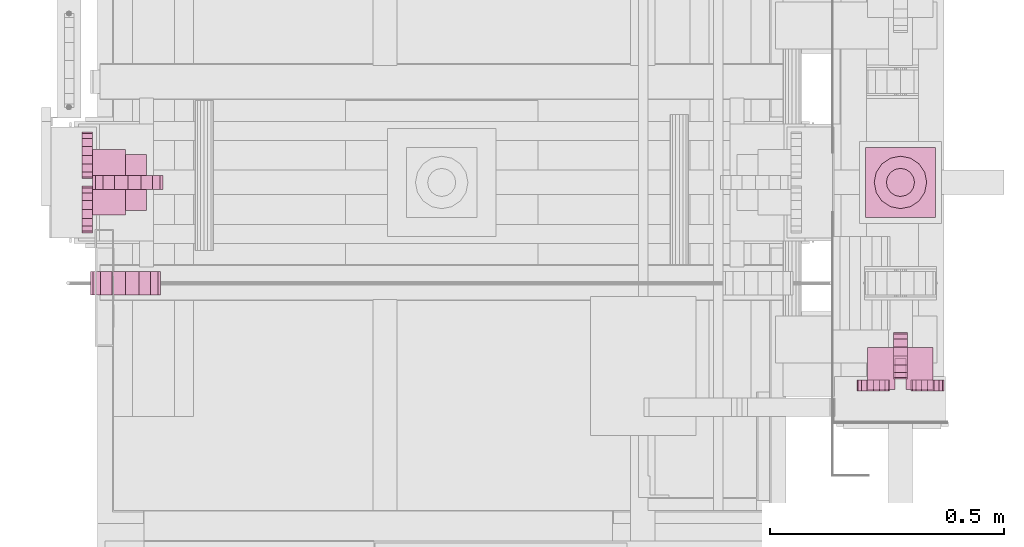
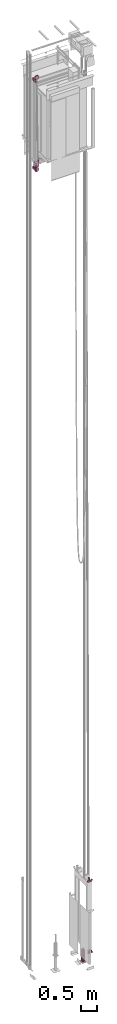
# One storey, part 10 of 13: 6 transport elements.
"""IFC4 building model written with IfcOpenShell, lengths in millimetres."""

from ifc_helpers import new_model, entity, si_unit, converted_unit, frame, origin_with_axes, place, context, subcontext, project, spatial, faceted_brep, element, save


model = new_model("IFC4")

# Units and contexts
context_of_model = context(None, 3, precision=0.01, world=origin_with_axes())
sub_context_1 = subcontext(context_of_model, None, None, "MODEL_VIEW")
sub_context_2 = subcontext(context_of_model, None, None, "MODEL_VIEW")
sub_context_3 = subcontext(context_of_model, None, None, "MODEL_VIEW")
sub_context_4 = subcontext(context_of_model, None, None, "MODEL_VIEW")
sub_context_5 = subcontext(context_of_model, None, None, "MODEL_VIEW")
sub_context_6 = subcontext(context_of_model, None, None, "MODEL_VIEW")
ifc_project = project(units=[converted_unit("PLANEANGLEUNIT", "degree", entity("IfcPlaneAngleMeasure", 0.017453292519943), si_unit("PLANEANGLEUNIT", "RADIAN"), dimensions=[0, 0, 0, 0, 0, 0, 0]), si_unit("LENGTHUNIT", "METRE", prefix="MILLI"), si_unit("MASSUNIT", "GRAM", prefix="KILO"), converted_unit("TIMEUNIT", "year", entity("IfcTimeMeasure", 31557600.0), si_unit("TIMEUNIT", "SECOND"), dimensions=[0, 0, 1, 0, 0, 0, 0]), si_unit("THERMODYNAMICTEMPERATUREUNIT", "DEGREE_CELSIUS"), si_unit("AREAUNIT", "SQUARE_METRE"), si_unit("FORCEUNIT", "NEWTON"), si_unit("VOLUMEUNIT", "CUBIC_METRE"), si_unit("PRESSUREUNIT", "PASCAL"), si_unit("SOLIDANGLEUNIT", "STERADIAN")], contexts=[context_of_model])

# Site, building, storey
site = spatial("IfcSite", under=ifc_project)
building = spatial("IfcBuilding", under=site, Name="Document")
placement = place(None, origin_with_axes())
storey_placement = place(placement, frame((0.0, 0.0, -26400.0), z_axis=(0.0, 0.0, 1.0), x_axis=(1.0, 0.0, 0.0)))
storey = spatial("IfcBuildingStorey", under=building, at=storey_placement, Name="Z -26400", Elevation=-26400.0)

# Transport elements
transport_element_1_placement = place(storey_placement, frame((1879.0, 1025.0, 0.0), z_axis=(0.0, 0.0, 1.0), x_axis=(0.0, 1.0, 0.0)))
element("IfcTransportElement", 1, at=transport_element_1_placement, inside=storey, ObjectType="MLB20", PredefinedType="ELEVATOR", context=sub_context_1, shape_type="Brep", body=[
    faceted_brep([(-75.0, -75.0, 0.0), (-75.0, 75.0, 0.0), (-75.0, 75.0, -16.0), (-75.0, -75.0, -16.0), (75.0, -75.0, 0.0), (75.0, -75.0, -16.0), (75.0, 75.0, -16.0), (75.0, 75.0, 0.0)], [[[0, 1, 2, 3]], [[4, 5, 6, 7]], [[0, 3, 5, 4]], [[3, 2, 6, 5]], [[2, 1, 7, 6]], [[1, 0, 4, 7]]]),
    faceted_brep([(-39.59796142578125, 39.5980224609375, 0.0), (-39.59796142578125, 39.5980224609375, 459.0), (-21.4302978515625, 51.7373046875, 459.0), (-21.4302978515625, 51.7373046875, 0.0), (0.0, 56.0, 0.0), (21.4302978515625, 51.7373046875, 0.0), (39.5980224609375, 39.5980224609375, 0.0), (51.7373046875, 21.4302978515625, 0.0), (56.0, 0.0, 0.0), (51.7373046875, -21.4302978515625, 0.0), (39.5980224609375, -39.5980224609375, 0.0), (21.4302978515625, -51.7373046875, 0.0), (0.0, -56.0, 0.0), (-21.4302978515625, -51.7373046875, 0.0), (-39.59796142578125, -39.5980224609375, 0.0), (-51.73724365234375, -21.4302978515625, 0.0), (-56.0, 0.0, 0.0), (-51.73724365234375, 21.4302978515625, 0.0), (0.0, 56.0, 459.0), (-51.73724365234375, 21.4302978515625, 459.0), (21.4302978515625, 51.7373046875, 459.0), (-56.0, 0.0, 459.0), (39.5980224609375, 39.5980224609375, 459.0), (-51.73724365234375, -21.4302978515625, 459.0), (51.7373046875, 21.4302978515625, 459.0), (-39.59796142578125, -39.5980224609375, 459.0), (56.0, 0.0, 459.0), (-21.4302978515625, -51.7373046875, 459.0), (51.7373046875, -21.4302978515625, 459.0), (0.0, -56.0, 459.0), (39.5980224609375, -39.5980224609375, 459.0), (21.4302978515625, -51.7373046875, 459.0)], [[[0, 1, 2, 3]], [[4, 5, 6, 7, 8, 9, 10, 11, 12, 13, 14, 15, 16, 17, 0, 3]], [[2, 18, 4, 3]], [[17, 19, 1, 0]], [[18, 20, 5, 4]], [[16, 21, 19, 17]], [[20, 22, 6, 5]], [[15, 23, 21, 16]], [[22, 24, 7, 6]], [[14, 25, 23, 15]], [[24, 26, 8, 7]], [[13, 27, 25, 14]], [[26, 28, 9, 8]], [[12, 29, 27, 13]], [[28, 30, 10, 9]], [[11, 31, 29, 12]], [[30, 31, 11, 10]], [[1, 19, 21, 23, 25, 27, 29, 31, 30, 28, 26, 24, 22, 20, 18, 2]]]),
    faceted_brep([(-15.909912109375, 15.909912109375, 459.0), (-15.909912109375, 15.909912109375, 479.0), (-8.6103515625, 20.7872314453125, 479.0), (-8.6103515625, 20.7872314453125, 459.0), (0.0, 22.5, 459.0), (8.6103515625, 20.7872314453125, 459.0), (15.909912109375, 15.909912109375, 459.0), (20.7872314453125, 8.6103515625, 459.0), (22.5, 0.0, 459.0), (20.7872314453125, -8.6103515625, 459.0), (15.909912109375, -15.909912109375, 459.0), (8.6103515625, -20.7872314453125, 459.0), (0.0, -22.5, 459.0), (-8.6103515625, -20.7872314453125, 459.0), (-15.909912109375, -15.909912109375, 459.0), (-20.78729248046875, -8.6103515625, 459.0), (-22.5, 0.0, 459.0), (-20.78729248046875, 8.6103515625, 459.0), (0.0, 22.5, 479.0), (-20.78729248046875, 8.6103515625, 479.0), (8.6103515625, 20.7872314453125, 479.0), (-22.5, 0.0, 479.0), (15.909912109375, 15.909912109375, 479.0), (-20.78729248046875, -8.6103515625, 479.0), (-15.909912109375, -15.909912109375, 479.0), (-8.6103515625, -20.7872314453125, 479.0), (0.0, -22.5, 479.0), (8.6103515625, -20.7872314453125, 479.0), (15.909912109375, -15.909912109375, 479.0), (20.7872314453125, -8.6103515625, 479.0), (22.5, 0.0, 479.0), (20.7872314453125, 8.6103515625, 479.0)], [[[0, 1, 2, 3]], [[4, 5, 6, 7, 8, 9, 10, 11, 12, 13, 14, 15, 16, 17, 0, 3]], [[2, 18, 4, 3]], [[17, 19, 1, 0]], [[18, 20, 5, 4]], [[16, 21, 19, 17]], [[20, 22, 6, 5]], [[1, 19, 21, 23, 24, 25, 26, 27, 28, 29, 30, 31, 22, 20, 18, 2]], [[15, 23, 21, 16]], [[22, 31, 7, 6]], [[14, 24, 23, 15]], [[31, 30, 8, 7]], [[13, 25, 24, 14]], [[30, 29, 9, 8]], [[12, 26, 25, 13]], [[29, 28, 10, 9]], [[11, 27, 26, 12]], [[28, 27, 11, 10]]]),
    faceted_brep([(-21.21319580078125, 21.2132568359375, 479.0), (-21.21319580078125, 21.2132568359375, 489.0), (-11.48052978515625, 27.7164306640625, 489.0), (-11.48052978515625, 27.7164306640625, 479.0), (0.0, 30.0, 479.0), (11.48046875, 27.7164306640625, 479.0), (21.2132568359375, 21.2132568359375, 479.0), (27.7164306640625, 11.48046875, 479.0), (30.0, 0.0, 479.0), (27.7164306640625, -11.48046875, 479.0), (21.2132568359375, -21.2132568359375, 479.0), (11.48046875, -27.7164306640625, 479.0), (0.0, -30.0, 479.0), (-11.48052978515625, -27.7164306640625, 479.0), (-21.21319580078125, -21.2132568359375, 479.0), (-27.71636962890625, -11.48046875, 479.0), (-30.0, 0.0, 479.0), (-27.71636962890625, 11.48046875, 479.0), (0.0, 30.0, 489.0), (-27.71636962890625, 11.48046875, 489.0), (11.48046875, 27.7164306640625, 489.0), (-30.0, 0.0, 489.0), (-27.71636962890625, -11.48046875, 489.0), (-21.21319580078125, -21.2132568359375, 489.0), (-11.48052978515625, -27.7164306640625, 489.0), (0.0, -30.0, 489.0), (11.48046875, -27.7164306640625, 489.0), (21.2132568359375, -21.2132568359375, 489.0), (27.7164306640625, -11.48046875, 489.0), (30.0, 0.0, 489.0), (27.7164306640625, 11.48046875, 489.0), (21.2132568359375, 21.2132568359375, 489.0)], [[[0, 1, 2, 3]], [[4, 5, 6, 7, 8, 9, 10, 11, 12, 13, 14, 15, 16, 17, 0, 3]], [[2, 18, 4, 3]], [[17, 19, 1, 0]], [[18, 20, 5, 4]], [[1, 19, 21, 22, 23, 24, 25, 26, 27, 28, 29, 30, 31, 20, 18, 2]], [[16, 21, 19, 17]], [[20, 31, 6, 5]], [[15, 22, 21, 16]], [[31, 30, 7, 6]], [[14, 23, 22, 15]], [[30, 29, 8, 7]], [[13, 24, 23, 14]], [[29, 28, 9, 8]], [[12, 25, 24, 13]], [[28, 27, 10, 9]], [[11, 26, 25, 12]], [[27, 26, 11, 10]]]),
])
transport_element_2_placement = place(storey_placement, frame((1879.0, 603.0, 649.0), z_axis=(0.0, 0.0, -1.0), x_axis=(1.0, 0.0, 0.0)))
element("IfcTransportElement", 2, at=transport_element_2_placement, inside=storey, ObjectType="R3", PredefinedType="ELEVATOR", context=sub_context_2, shape_type="Brep", body=[
    faceted_brep([(-70.0, 20.0, 0.0), (-70.0, -70.0, 0.0), (-70.0, -70.0, 10.0), (-70.0, 20.0, 10.0), (-12.0, -46.0, 10.0), (-12.0, -46.0, 0.0), (-12.0, 20.0, 0.0), (-12.0, 20.0, 10.0), (12.0, 20.0, 0.0), (12.0, -46.0, 0.0), (12.0, -46.0, 10.0), (12.0, 20.0, 10.0), (70.0, -70.0, 10.0), (70.0, -70.0, 0.0), (70.0, 20.0, 0.0), (70.0, 20.0, 10.0)], [[[0, 1, 2, 3]], [[4, 5, 6, 7]], [[8, 9, 10, 11]], [[12, 13, 14, 15]], [[7, 6, 0, 3]], [[1, 13, 12, 2]], [[15, 14, 8, 11]], [[10, 9, 5, 4]], [[2, 12, 15, 11, 10, 4, 7, 3]], [[6, 5, 9, 8, 14, 13, 1, 0]]]),
    faceted_brep([(22.93994140625, 23.0, 58.0), (25.604248046875, 23.0, 71.3939208984375), (33.1912841796875, 23.0, 82.74871826171875), (44.5460205078125, 23.0, 90.33575439453125), (57.93994140625, 23.0, 93.0), (71.3338623046875, 23.0, 90.33575439453125), (82.688720703125, 23.0, 82.74871826171875), (90.2757568359375, 23.0, 71.3939208984375), (92.93994140625, 23.0, 58.0), (90.2757568359375, 23.0, 44.6060791015625), (82.688720703125, 23.0, 33.25128173828125), (71.3338623046875, 23.0, 25.66424560546875), (57.93994140625, 23.0, 23.0), (44.5460205078125, 23.0, 25.66424560546875), (33.1912841796875, 23.0, 33.25128173828125), (25.604248046875, 23.0, 44.6060791015625), (22.93994140625, 0.0, 58.0), (25.604248046875, 0.0, 44.6060791015625), (33.1912841796875, 0.0, 33.25128173828125), (44.5460205078125, 0.0, 25.66424560546875), (57.93994140625, 0.0, 23.0), (71.3338623046875, 0.0, 25.66424560546875), (82.688720703125, 0.0, 33.25128173828125), (90.2757568359375, 0.0, 44.6060791015625), (92.93994140625, 0.0, 58.0), (90.2757568359375, 0.0, 71.3939208984375), (82.688720703125, 0.0, 82.74871826171875), (71.3338623046875, 0.0, 90.33575439453125), (57.93994140625, 0.0, 93.0), (44.5460205078125, 0.0, 90.33575439453125), (33.1912841796875, 0.0, 82.74871826171875), (25.604248046875, 0.0, 71.3939208984375)], [[[0, 1, 2, 3, 4, 5, 6, 7, 8, 9, 10, 11, 12, 13, 14, 15]], [[16, 17, 18, 19, 20, 21, 22, 23, 24, 25, 26, 27, 28, 29, 30, 31]], [[0, 15, 17, 16]], [[15, 14, 18, 17]], [[14, 13, 19, 18]], [[13, 12, 20, 19]], [[12, 11, 21, 20]], [[11, 10, 22, 21]], [[10, 9, 23, 22]], [[9, 8, 24, 23]], [[8, 7, 25, 24]], [[7, 6, 26, 25]], [[6, 5, 27, 26]], [[5, 4, 28, 27]], [[4, 3, 29, 28]], [[3, 2, 30, 29]], [[2, 1, 31, 30]], [[1, 0, 16, 31]]]),
    faceted_brep([(-92.93994140625, 0.0, 58.0), (-90.2757568359375, 0.0, 44.6060791015625), (-82.688720703125, 0.0, 33.25128173828125), (-71.3338623046875, 0.0, 25.66424560546875), (-57.93994140625, 0.0, 23.0), (-44.5460205078125, 0.0, 25.66424560546875), (-33.1912841796875, 0.0, 33.25128173828125), (-25.604248046875, 0.0, 44.6060791015625), (-22.93994140625, 0.0, 58.0), (-25.604248046875, 0.0, 71.3939208984375), (-33.1912841796875, 0.0, 82.74871826171875), (-44.5460205078125, 0.0, 90.33575439453125), (-57.93994140625, 0.0, 93.0), (-71.3338623046875, 0.0, 90.33575439453125), (-82.688720703125, 0.0, 82.74871826171875), (-90.2757568359375, 0.0, 71.3939208984375), (-92.93994140625, 23.0, 58.0), (-90.2757568359375, 23.0, 71.3939208984375), (-82.688720703125, 23.0, 82.74871826171875), (-71.3338623046875, 23.0, 90.33575439453125), (-57.93994140625, 23.0, 93.0), (-44.5460205078125, 23.0, 90.33575439453125), (-33.1912841796875, 23.0, 82.74871826171875), (-25.604248046875, 23.0, 71.3939208984375), (-22.93994140625, 23.0, 58.0), (-25.604248046875, 23.0, 44.6060791015625), (-33.1912841796875, 23.0, 33.25128173828125), (-44.5460205078125, 23.0, 25.66424560546875), (-57.93994140625, 23.0, 23.0), (-71.3338623046875, 23.0, 25.66424560546875), (-82.688720703125, 23.0, 33.25128173828125), (-90.2757568359375, 23.0, 44.6060791015625)], [[[0, 1, 2, 3, 4, 5, 6, 7, 8, 9, 10, 11, 12, 13, 14, 15]], [[16, 17, 18, 19, 20, 21, 22, 23, 24, 25, 26, 27, 28, 29, 30, 31]], [[0, 15, 17, 16]], [[15, 14, 18, 17]], [[14, 13, 19, 18]], [[13, 12, 20, 19]], [[12, 11, 21, 20]], [[11, 10, 22, 21]], [[10, 9, 23, 22]], [[9, 8, 24, 23]], [[8, 7, 25, 24]], [[7, 6, 26, 25]], [[6, 5, 27, 26]], [[5, 4, 28, 27]], [[4, 3, 29, 28]], [[3, 2, 30, 29]], [[2, 1, 31, 30]], [[1, 0, 16, 31]]]),
    faceted_brep([(15.0, -52.0, 43.0), (15.0, -32.8658447265625, 46.8060302734375), (15.0, -16.6446533203125, 57.6446533203125), (15.0, -5.8060302734375, 73.8658447265625), (15.0, -2.0, 93.0), (15.0, -5.8060302734375, 112.1341552734375), (15.0, -16.6446533203125, 128.3553466796875), (15.0, -32.8658447265625, 139.1939697265625), (15.0, -52.0, 143.0), (15.0, -71.1341552734375, 139.1939697265625), (15.0, -87.3553466796875, 128.3553466796875), (15.0, -98.1939697265625, 112.1341552734375), (15.0, -102.0, 93.0), (15.0, -98.1939697265625, 73.8658447265625), (15.0, -87.3553466796875, 57.6446533203125), (15.0, -71.1341552734375, 46.8060302734375), (-15.0, -52.0, 43.0), (-15.0, -71.1341552734375, 46.8060302734375), (-15.0, -87.3553466796875, 57.6446533203125), (-15.0, -98.1939697265625, 73.8658447265625), (-15.0, -102.0, 93.0), (-15.0, -98.1939697265625, 112.1341552734375), (-15.0, -87.3553466796875, 128.3553466796875), (-15.0, -71.1341552734375, 139.1939697265625), (-15.0, -52.0, 143.0), (-15.0, -32.8658447265625, 139.1939697265625), (-15.0, -16.6446533203125, 128.3553466796875), (-15.0, -5.8060302734375, 112.1341552734375), (-15.0, -2.0, 93.0), (-15.0, -5.8060302734375, 73.8658447265625), (-15.0, -16.6446533203125, 57.6446533203125), (-15.0, -32.8658447265625, 46.8060302734375)], [[[0, 1, 2, 3, 4, 5, 6, 7, 8, 9, 10, 11, 12, 13, 14, 15]], [[16, 17, 18, 19, 20, 21, 22, 23, 24, 25, 26, 27, 28, 29, 30, 31]], [[0, 15, 17, 16]], [[15, 14, 18, 17]], [[14, 13, 19, 18]], [[13, 12, 20, 19]], [[12, 11, 21, 20]], [[11, 10, 22, 21]], [[10, 9, 23, 22]], [[9, 8, 24, 23]], [[8, 7, 25, 24]], [[7, 6, 26, 25]], [[6, 5, 27, 26]], [[5, 4, 28, 27]], [[4, 3, 29, 28]], [[3, 2, 30, 29]], [[2, 1, 31, 30]], [[1, 0, 16, 31]]]),
])
transport_element_3_placement = place(storey_placement, frame((1879.0, 603.0, 3249.0), z_axis=(0.0, 0.0, 1.0), x_axis=(-1.0, 0.0, 0.0)))
element("IfcTransportElement", 3, at=transport_element_3_placement, inside=storey, ObjectType="R3", PredefinedType="ELEVATOR", context=sub_context_3, shape_type="Brep", body=[
    faceted_brep([(15.0, -52.0, 43.0), (15.0, -32.8658447265625, 46.805908203125), (15.0, -16.6446533203125, 57.644775390625), (15.0, -5.8060302734375, 73.86572265625), (15.0, -2.0, 93.0), (15.0, -5.8060302734375, 112.13427734375), (15.0, -16.6446533203125, 128.355224609375), (15.0, -32.8658447265625, 139.194091796875), (15.0, -52.0, 143.0), (15.0, -71.1341552734375, 139.194091796875), (15.0, -87.3553466796875, 128.355224609375), (15.0, -98.1939697265625, 112.13427734375), (15.0, -102.0, 93.0), (15.0, -98.1939697265625, 73.86572265625), (15.0, -87.3553466796875, 57.644775390625), (15.0, -71.1341552734375, 46.805908203125), (-15.0, -52.0, 43.0), (-15.0, -71.1341552734375, 46.805908203125), (-15.0, -87.3553466796875, 57.644775390625), (-15.0, -98.1939697265625, 73.86572265625), (-15.0, -102.0, 93.0), (-15.0, -98.1939697265625, 112.13427734375), (-15.0, -87.3553466796875, 128.355224609375), (-15.0, -71.1341552734375, 139.194091796875), (-15.0, -52.0, 143.0), (-15.0, -32.8658447265625, 139.194091796875), (-15.0, -16.6446533203125, 128.355224609375), (-15.0, -5.8060302734375, 112.13427734375), (-15.0, -2.0, 93.0), (-15.0, -5.8060302734375, 73.86572265625), (-15.0, -16.6446533203125, 57.644775390625), (-15.0, -32.8658447265625, 46.805908203125)], [[[0, 1, 2, 3, 4, 5, 6, 7, 8, 9, 10, 11, 12, 13, 14, 15]], [[16, 17, 18, 19, 20, 21, 22, 23, 24, 25, 26, 27, 28, 29, 30, 31]], [[0, 15, 17, 16]], [[15, 14, 18, 17]], [[14, 13, 19, 18]], [[13, 12, 20, 19]], [[12, 11, 21, 20]], [[11, 10, 22, 21]], [[10, 9, 23, 22]], [[9, 8, 24, 23]], [[8, 7, 25, 24]], [[7, 6, 26, 25]], [[6, 5, 27, 26]], [[5, 4, 28, 27]], [[4, 3, 29, 28]], [[3, 2, 30, 29]], [[2, 1, 31, 30]], [[1, 0, 16, 31]]]),
    faceted_brep([(-92.93994140625, 0.0, 58.0), (-90.2757568359375, 0.0, 44.606201171875), (-82.688720703125, 0.0, 33.251220703125), (-71.3338623046875, 0.0, 25.664306640625), (-57.93994140625, 0.0, 23.0), (-44.5460205078125, 0.0, 25.664306640625), (-33.1912841796875, 0.0, 33.251220703125), (-25.604248046875, 0.0, 44.606201171875), (-22.93994140625, 0.0, 58.0), (-25.604248046875, 0.0, 71.393798828125), (-33.1912841796875, 0.0, 82.748779296875), (-44.5460205078125, 0.0, 90.335693359375), (-57.93994140625, 0.0, 93.0), (-71.3338623046875, 0.0, 90.335693359375), (-82.688720703125, 0.0, 82.748779296875), (-90.2757568359375, 0.0, 71.393798828125), (-92.93994140625, 23.0, 58.0), (-90.2757568359375, 23.0, 71.393798828125), (-82.688720703125, 23.0, 82.748779296875), (-71.3338623046875, 23.0, 90.335693359375), (-57.93994140625, 23.0, 93.0), (-44.5460205078125, 23.0, 90.335693359375), (-33.1912841796875, 23.0, 82.748779296875), (-25.604248046875, 23.0, 71.393798828125), (-22.93994140625, 23.0, 58.0), (-25.604248046875, 23.0, 44.606201171875), (-33.1912841796875, 23.0, 33.251220703125), (-44.5460205078125, 23.0, 25.664306640625), (-57.93994140625, 23.0, 23.0), (-71.3338623046875, 23.0, 25.664306640625), (-82.688720703125, 23.0, 33.251220703125), (-90.2757568359375, 23.0, 44.606201171875)], [[[0, 1, 2, 3, 4, 5, 6, 7, 8, 9, 10, 11, 12, 13, 14, 15]], [[16, 17, 18, 19, 20, 21, 22, 23, 24, 25, 26, 27, 28, 29, 30, 31]], [[0, 15, 17, 16]], [[15, 14, 18, 17]], [[14, 13, 19, 18]], [[13, 12, 20, 19]], [[12, 11, 21, 20]], [[11, 10, 22, 21]], [[10, 9, 23, 22]], [[9, 8, 24, 23]], [[8, 7, 25, 24]], [[7, 6, 26, 25]], [[6, 5, 27, 26]], [[5, 4, 28, 27]], [[4, 3, 29, 28]], [[3, 2, 30, 29]], [[2, 1, 31, 30]], [[1, 0, 16, 31]]]),
    faceted_brep([(22.93994140625, 23.0, 58.0), (25.604248046875, 23.0, 71.393798828125), (33.1912841796875, 23.0, 82.748779296875), (44.5460205078125, 23.0, 90.335693359375), (57.93994140625, 23.0, 93.0), (71.3338623046875, 23.0, 90.335693359375), (82.688720703125, 23.0, 82.748779296875), (90.2757568359375, 23.0, 71.393798828125), (92.93994140625, 23.0, 58.0), (90.2757568359375, 23.0, 44.606201171875), (82.688720703125, 23.0, 33.251220703125), (71.3338623046875, 23.0, 25.664306640625), (57.93994140625, 23.0, 23.0), (44.5460205078125, 23.0, 25.664306640625), (33.1912841796875, 23.0, 33.251220703125), (25.604248046875, 23.0, 44.606201171875), (22.93994140625, 0.0, 58.0), (25.604248046875, 0.0, 44.606201171875), (33.1912841796875, 0.0, 33.251220703125), (44.5460205078125, 0.0, 25.664306640625), (57.93994140625, 0.0, 23.0), (71.3338623046875, 0.0, 25.664306640625), (82.688720703125, 0.0, 33.251220703125), (90.2757568359375, 0.0, 44.606201171875), (92.93994140625, 0.0, 58.0), (90.2757568359375, 0.0, 71.393798828125), (82.688720703125, 0.0, 82.748779296875), (71.3338623046875, 0.0, 90.335693359375), (57.93994140625, 0.0, 93.0), (44.5460205078125, 0.0, 90.335693359375), (33.1912841796875, 0.0, 82.748779296875), (25.604248046875, 0.0, 71.393798828125)], [[[0, 1, 2, 3, 4, 5, 6, 7, 8, 9, 10, 11, 12, 13, 14, 15]], [[16, 17, 18, 19, 20, 21, 22, 23, 24, 25, 26, 27, 28, 29, 30, 31]], [[0, 15, 17, 16]], [[15, 14, 18, 17]], [[14, 13, 19, 18]], [[13, 12, 20, 19]], [[12, 11, 21, 20]], [[11, 10, 22, 21]], [[10, 9, 23, 22]], [[9, 8, 24, 23]], [[8, 7, 25, 24]], [[7, 6, 26, 25]], [[6, 5, 27, 26]], [[5, 4, 28, 27]], [[4, 3, 29, 28]], [[3, 2, 30, 29]], [[2, 1, 31, 30]], [[1, 0, 16, 31]]]),
    faceted_brep([(70.0, 20.0, 10.0), (70.0, -70.0, 10.0), (70.0, -70.0, 0.0), (70.0, 20.0, 0.0), (12.0, -46.0, 0.0), (12.0, -46.0, 10.0), (12.0, 20.0, 10.0), (12.0, 20.0, 0.0), (-12.0, 20.0, 10.0), (-12.0, -46.0, 10.0), (-12.0, -46.0, 0.0), (-12.0, 20.0, 0.0), (-70.0, -70.0, 0.0), (-70.0, -70.0, 10.0), (-70.0, 20.0, 10.0), (-70.0, 20.0, 0.0)], [[[0, 1, 2, 3]], [[4, 5, 6, 7]], [[8, 9, 10, 11]], [[12, 13, 14, 15]], [[7, 6, 0, 3]], [[1, 13, 12, 2]], [[15, 14, 8, 11]], [[10, 9, 5, 4]], [[2, 12, 15, 11, 10, 4, 7, 3]], [[6, 5, 9, 8, 14, 13, 1, 0]]]),
])
transport_element_4_placement = place(storey_placement, frame((155.0, 1025.0, 30670.0), z_axis=(0.0, 0.0, -1.0), x_axis=(0.0, -1.0, 0.0)))
element("IfcTransportElement", 4, at=transport_element_4_placement, inside=storey, ObjectType="Car Guide shoe Bottom", PredefinedType="ELEVATOR", context=sub_context_4, shape_type="Brep", body=[
    faceted_brep([(15.0, -75.0, 204.0), (15.0, -46.298736572265625, 209.708984375), (15.0, -21.966995239257812, 225.966796875), (15.0, -5.709030151367188, 250.298828125), (15.0, 0.0, 279.0), (15.0, -5.709030151367188, 307.701171875), (15.0, -21.966995239257812, 332.033203125), (15.0, -46.298736572265625, 348.291015625), (15.0, -75.0, 354.0), (15.0, -103.70126342773438, 348.291015625), (15.0, -128.03302001953125, 332.033203125), (15.0, -144.29095458984375, 307.701171875), (15.0, -150.0, 279.0), (15.0, -144.29095458984375, 250.298828125), (15.0, -128.03302001953125, 225.966796875), (15.0, -103.70126342773438, 209.708984375), (-15.0, -75.0, 204.0), (-15.0, -103.70126342773438, 209.708984375), (-15.0, -128.03302001953125, 225.966796875), (-15.0, -144.29095458984375, 250.298828125), (-15.0, -150.0, 279.0), (-15.0, -144.29095458984375, 307.701171875), (-15.0, -128.03302001953125, 332.033203125), (-15.0, -103.70126342773438, 348.291015625), (-15.0, -75.0, 354.0), (-15.0, -46.298736572265625, 348.291015625), (-15.0, -21.966995239257812, 332.033203125), (-15.0, -5.709030151367188, 307.701171875), (-15.0, 0.0, 279.0), (-15.0, -5.709030151367188, 250.298828125), (-15.0, -21.966995239257812, 225.966796875), (-15.0, -46.298736572265625, 209.708984375)], [[[0, 1, 2, 3, 4, 5, 6, 7, 8, 9, 10, 11, 12, 13, 14, 15]], [[16, 17, 18, 19, 20, 21, 22, 23, 24, 25, 26, 27, 28, 29, 30, 31]], [[0, 15, 17, 16]], [[15, 14, 18, 17]], [[14, 13, 19, 18]], [[13, 12, 20, 19]], [[12, 11, 21, 20]], [[11, 10, 22, 21]], [[10, 9, 23, 22]], [[9, 8, 24, 23]], [[8, 7, 25, 24]], [[7, 6, 26, 25]], [[6, 5, 27, 26]], [[5, 4, 28, 27]], [[4, 3, 29, 28]], [[3, 2, 30, 29]], [[2, 1, 31, 30]], [[1, 0, 16, 31]]]),
    faceted_brep([(-107.93994140625, 0.0, 213.0), (-104.134033203125, 0.0, 193.865234375), (-93.2952880859375, 0.0, 177.64453125), (-77.07421875, 0.0, 166.806640625), (-57.93994140625, 0.0, 163.0), (-38.8057861328125, 0.0, 166.806640625), (-22.584716796875, 0.0, 177.64453125), (-11.7459716796875, 0.0, 193.865234375), (-7.93994140625, 0.0, 213.0), (-11.7459716796875, 0.0, 232.134765625), (-22.584716796875, 0.0, 248.35546875), (-38.8057861328125, 0.0, 259.193359375), (-57.93994140625, 0.0, 263.0), (-77.07421875, 0.0, 259.193359375), (-93.2952880859375, 0.0, 248.35546875), (-104.134033203125, 0.0, 232.134765625), (-107.93994140625, 23.0, 213.0), (-104.134033203125, 23.0, 232.134765625), (-93.2952880859375, 23.0, 248.35546875), (-77.07421875, 23.0, 259.193359375), (-57.93994140625, 23.0, 263.0), (-38.8057861328125, 23.0, 259.193359375), (-22.584716796875, 23.0, 248.35546875), (-11.7459716796875, 23.0, 232.134765625), (-7.93994140625, 23.0, 213.0), (-11.7459716796875, 23.0, 193.865234375), (-22.584716796875, 23.0, 177.64453125), (-38.8057861328125, 23.0, 166.806640625), (-57.93994140625, 23.0, 163.0), (-77.07421875, 23.0, 166.806640625), (-93.2952880859375, 23.0, 177.64453125), (-104.134033203125, 23.0, 193.865234375)], [[[0, 1, 2, 3, 4, 5, 6, 7, 8, 9, 10, 11, 12, 13, 14, 15]], [[16, 17, 18, 19, 20, 21, 22, 23, 24, 25, 26, 27, 28, 29, 30, 31]], [[0, 15, 17, 16]], [[15, 14, 18, 17]], [[14, 13, 19, 18]], [[13, 12, 20, 19]], [[12, 11, 21, 20]], [[11, 10, 22, 21]], [[10, 9, 23, 22]], [[9, 8, 24, 23]], [[8, 7, 25, 24]], [[7, 6, 26, 25]], [[6, 5, 27, 26]], [[5, 4, 28, 27]], [[4, 3, 29, 28]], [[3, 2, 30, 29]], [[2, 1, 31, 30]], [[1, 0, 16, 31]]]),
    faceted_brep([(-60.0, -15.0, 0.0), (-60.0, -115.0, 0.0), (-60.0, -115.0, 145.0), (-60.0, -15.0, 145.0), (60.0, -15.0, 0.0), (60.0, -15.0, 145.0), (60.0, -115.0, 145.0), (60.0, -115.0, 0.0)], [[[0, 1, 2, 3]], [[4, 5, 6, 7]], [[0, 3, 5, 4]], [[3, 2, 6, 5]], [[2, 1, 7, 6]], [[1, 0, 4, 7]]]),
    faceted_brep([(7.94000244140625, 23.0, 213.0), (11.74603271484375, 23.0, 232.134765625), (22.58465576171875, 23.0, 248.35546875), (38.80584716796875, 23.0, 259.193359375), (57.94000244140625, 23.0, 263.0), (77.07415771484375, 23.0, 259.193359375), (93.29534912109375, 23.0, 248.35546875), (104.13397216796875, 23.0, 232.134765625), (107.94000244140625, 23.0, 213.0), (104.13397216796875, 23.0, 193.865234375), (93.29534912109375, 23.0, 177.64453125), (77.07415771484375, 23.0, 166.806640625), (57.94000244140625, 23.0, 163.0), (38.80584716796875, 23.0, 166.806640625), (22.58465576171875, 23.0, 177.64453125), (11.74603271484375, 23.0, 193.865234375), (7.94000244140625, 0.0, 213.0), (11.74603271484375, 0.0, 193.865234375), (22.58465576171875, 0.0, 177.64453125), (38.80584716796875, 0.0, 166.806640625), (57.94000244140625, 0.0, 163.0), (77.07415771484375, 0.0, 166.806640625), (93.29534912109375, 0.0, 177.64453125), (104.13397216796875, 0.0, 193.865234375), (107.94000244140625, 0.0, 213.0), (104.13397216796875, 0.0, 232.134765625), (93.29534912109375, 0.0, 248.35546875), (77.07415771484375, 0.0, 259.193359375), (57.94000244140625, 0.0, 263.0), (38.80584716796875, 0.0, 259.193359375), (22.58465576171875, 0.0, 248.35546875), (11.74603271484375, 0.0, 232.134765625)], [[[0, 1, 2, 3, 4, 5, 6, 7, 8, 9, 10, 11, 12, 13, 14, 15]], [[16, 17, 18, 19, 20, 21, 22, 23, 24, 25, 26, 27, 28, 29, 30, 31]], [[0, 15, 17, 16]], [[15, 14, 18, 17]], [[14, 13, 19, 18]], [[13, 12, 20, 19]], [[12, 11, 21, 20]], [[11, 10, 22, 21]], [[10, 9, 23, 22]], [[9, 8, 24, 23]], [[8, 7, 25, 24]], [[7, 6, 26, 25]], [[6, 5, 27, 26]], [[5, 4, 28, 27]], [[4, 3, 29, 28]], [[3, 2, 30, 29]], [[2, 1, 31, 30]], [[1, 0, 16, 31]]]),
    faceted_brep([(70.0, 20.0, 145.0), (12.0, 20.0, 145.0), (12.0, 20.0, 155.0), (70.0, 20.0, 155.0), (-12.0, 20.0, 145.0), (-70.0, 20.0, 145.0), (-70.0, 20.0, 155.0), (-12.0, 20.0, 155.0), (-70.0, -70.0, 155.0), (-70.0, -70.0, 145.0), (70.0, -70.0, 145.0), (70.0, -70.0, 155.0), (12.0, -46.0, 145.0), (-12.0, -46.0, 145.0), (-12.0, -46.0, 155.0), (12.0, -46.0, 155.0)], [[[0, 1, 2, 3]], [[4, 5, 6, 7]], [[8, 9, 10, 11]], [[12, 13, 14, 15]], [[11, 10, 0, 3]], [[1, 12, 15, 2]], [[14, 13, 4, 7]], [[5, 9, 8, 6]], [[2, 15, 14, 7, 6, 8, 11, 3]], [[10, 9, 5, 4, 13, 12, 1, 0]]]),
])
transport_element_5_placement = place(storey_placement, frame((155.0, 1025.0, 33729.0), z_axis=(0.0, 0.0, 1.0), x_axis=(0.0, 1.0, 0.0)))
element("IfcTransportElement", 5, at=transport_element_5_placement, inside=storey, ObjectType="Car Guide shoe Top", PredefinedType="ELEVATOR", context=sub_context_5, shape_type="Brep", body=[
    faceted_brep([(15.0, -75.0, 59.0), (15.0, -46.298736572265625, 64.7109375), (15.0, -21.966995239257812, 80.96875), (15.0, -5.709030151367188, 105.296875), (15.0, 0.0, 134.0), (15.0, -5.709030151367188, 162.703125), (15.0, -21.966995239257812, 187.03125), (15.0, -46.298736572265625, 203.2890625), (15.0, -75.0, 209.0), (15.0, -103.70126342773438, 203.2890625), (15.0, -128.03302001953125, 187.03125), (15.0, -144.29095458984375, 162.703125), (15.0, -150.0, 134.0), (15.0, -144.29095458984375, 105.296875), (15.0, -128.03302001953125, 80.96875), (15.0, -103.70126342773438, 64.7109375), (-15.0, -75.0, 59.0), (-15.0, -103.70126342773438, 64.7109375), (-15.0, -128.03302001953125, 80.96875), (-15.0, -144.29095458984375, 105.296875), (-15.0, -150.0, 134.0), (-15.0, -144.29095458984375, 162.703125), (-15.0, -128.03302001953125, 187.03125), (-15.0, -103.70126342773438, 203.2890625), (-15.0, -75.0, 209.0), (-15.0, -46.298736572265625, 203.2890625), (-15.0, -21.966995239257812, 187.03125), (-15.0, -5.709030151367188, 162.703125), (-15.0, 0.0, 134.0), (-15.0, -5.709030151367188, 105.296875), (-15.0, -21.966995239257812, 80.96875), (-15.0, -46.298736572265625, 64.7109375)], [[[0, 1, 2, 3, 4, 5, 6, 7, 8, 9, 10, 11, 12, 13, 14, 15]], [[16, 17, 18, 19, 20, 21, 22, 23, 24, 25, 26, 27, 28, 29, 30, 31]], [[0, 15, 17, 16]], [[15, 14, 18, 17]], [[14, 13, 19, 18]], [[13, 12, 20, 19]], [[12, 11, 21, 20]], [[11, 10, 22, 21]], [[10, 9, 23, 22]], [[9, 8, 24, 23]], [[8, 7, 25, 24]], [[7, 6, 26, 25]], [[6, 5, 27, 26]], [[5, 4, 28, 27]], [[4, 3, 29, 28]], [[3, 2, 30, 29]], [[2, 1, 31, 30]], [[1, 0, 16, 31]]]),
    faceted_brep([(-70.0, 20.0, 10.0), (-12.0, 20.0, 10.0), (-12.0, 20.0, 0.0), (-70.0, 20.0, 0.0), (12.0, 20.0, 10.0), (70.0, 20.0, 10.0), (70.0, 20.0, 0.0), (12.0, 20.0, 0.0), (70.0, -70.0, 0.0), (70.0, -70.0, 10.0), (-70.0, -70.0, 10.0), (-70.0, -70.0, 0.0), (-12.0, -46.0, 10.0), (12.0, -46.0, 10.0), (12.0, -46.0, 0.0), (-12.0, -46.0, 0.0)], [[[0, 1, 2, 3]], [[4, 5, 6, 7]], [[8, 9, 10, 11]], [[12, 13, 14, 15]], [[11, 10, 0, 3]], [[1, 12, 15, 2]], [[14, 13, 4, 7]], [[5, 9, 8, 6]], [[2, 15, 14, 7, 6, 8, 11, 3]], [[10, 9, 5, 4, 13, 12, 1, 0]]]),
    faceted_brep([(-107.94000244140625, 0.0, 68.0), (-104.13397216796875, 0.0, 48.8671875), (-93.29534912109375, 0.0, 32.64453125), (-77.07415771484375, 0.0, 21.8046875), (-57.94000244140625, 0.0, 18.0), (-38.80584716796875, 0.0, 21.8046875), (-22.58465576171875, 0.0, 32.64453125), (-11.74603271484375, 0.0, 48.8671875), (-7.94000244140625, 0.0, 68.0), (-11.74603271484375, 0.0, 87.1328125), (-22.58465576171875, 0.0, 103.35546875), (-38.80584716796875, 0.0, 114.1953125), (-57.94000244140625, 0.0, 118.0), (-77.07415771484375, 0.0, 114.1953125), (-93.29534912109375, 0.0, 103.35546875), (-104.13397216796875, 0.0, 87.1328125), (-107.94000244140625, 23.0, 68.0), (-104.13397216796875, 23.0, 87.1328125), (-93.29534912109375, 23.0, 103.35546875), (-77.07415771484375, 23.0, 114.1953125), (-57.94000244140625, 23.0, 118.0), (-38.80584716796875, 23.0, 114.1953125), (-22.58465576171875, 23.0, 103.35546875), (-11.74603271484375, 23.0, 87.1328125), (-7.94000244140625, 23.0, 68.0), (-11.74603271484375, 23.0, 48.8671875), (-22.58465576171875, 23.0, 32.64453125), (-38.80584716796875, 23.0, 21.8046875), (-57.94000244140625, 23.0, 18.0), (-77.07415771484375, 23.0, 21.8046875), (-93.29534912109375, 23.0, 32.64453125), (-104.13397216796875, 23.0, 48.8671875)], [[[0, 1, 2, 3, 4, 5, 6, 7, 8, 9, 10, 11, 12, 13, 14, 15]], [[16, 17, 18, 19, 20, 21, 22, 23, 24, 25, 26, 27, 28, 29, 30, 31]], [[0, 15, 17, 16]], [[15, 14, 18, 17]], [[14, 13, 19, 18]], [[13, 12, 20, 19]], [[12, 11, 21, 20]], [[11, 10, 22, 21]], [[10, 9, 23, 22]], [[9, 8, 24, 23]], [[8, 7, 25, 24]], [[7, 6, 26, 25]], [[6, 5, 27, 26]], [[5, 4, 28, 27]], [[4, 3, 29, 28]], [[3, 2, 30, 29]], [[2, 1, 31, 30]], [[1, 0, 16, 31]]]),
    faceted_brep([(7.93994140625, 23.0, 68.0), (11.7459716796875, 23.0, 87.1328125), (22.584716796875, 23.0, 103.35546875), (38.8057861328125, 23.0, 114.1953125), (57.93994140625, 23.0, 118.0), (77.07421875, 23.0, 114.1953125), (93.2952880859375, 23.0, 103.35546875), (104.134033203125, 23.0, 87.1328125), (107.93994140625, 23.0, 68.0), (104.134033203125, 23.0, 48.8671875), (93.2952880859375, 23.0, 32.64453125), (77.07421875, 23.0, 21.8046875), (57.93994140625, 23.0, 18.0), (38.8057861328125, 23.0, 21.8046875), (22.584716796875, 23.0, 32.64453125), (11.7459716796875, 23.0, 48.8671875), (7.93994140625, 0.0, 68.0), (11.7459716796875, 0.0, 48.8671875), (22.584716796875, 0.0, 32.64453125), (38.8057861328125, 0.0, 21.8046875), (57.93994140625, 0.0, 18.0), (77.07421875, 0.0, 21.8046875), (93.2952880859375, 0.0, 32.64453125), (104.134033203125, 0.0, 48.8671875), (107.93994140625, 0.0, 68.0), (104.134033203125, 0.0, 87.1328125), (93.2952880859375, 0.0, 103.35546875), (77.07421875, 0.0, 114.1953125), (57.93994140625, 0.0, 118.0), (38.8057861328125, 0.0, 114.1953125), (22.584716796875, 0.0, 103.35546875), (11.7459716796875, 0.0, 87.1328125)], [[[0, 1, 2, 3, 4, 5, 6, 7, 8, 9, 10, 11, 12, 13, 14, 15]], [[16, 17, 18, 19, 20, 21, 22, 23, 24, 25, 26, 27, 28, 29, 30, 31]], [[0, 15, 17, 16]], [[15, 14, 18, 17]], [[14, 13, 19, 18]], [[13, 12, 20, 19]], [[12, 11, 21, 20]], [[11, 10, 22, 21]], [[10, 9, 23, 22]], [[9, 8, 24, 23]], [[8, 7, 25, 24]], [[7, 6, 26, 25]], [[6, 5, 27, 26]], [[5, 4, 28, 27]], [[4, 3, 29, 28]], [[3, 2, 30, 29]], [[2, 1, 31, 30]], [[1, 0, 16, 31]]]),
])
transport_element_6_placement = place(storey_placement, frame((225.0, 810.0, 30872.0), z_axis=(0.0, 0.0, -1.0), x_axis=(0.0, 1.0, 0.0)))
element("IfcTransportElement", 6, at=transport_element_6_placement, inside=storey, ObjectType="S5500 below", PredefinedType="ELEVATOR", context=sub_context_6, shape_type="Brep", body=[
    faceted_brep([(-25.0, 0.0, 75.0), (-25.0, 28.701263427734375, 69.291015625), (-25.0, 53.03302001953125, 53.033203125), (-25.0, 69.29095458984375, 28.701171875), (-25.0, 75.0, 0.0), (-25.0, 69.29095458984375, -28.701171875), (-25.0, 53.03302001953125, -53.033203125), (-25.0, 28.701263427734375, -69.291015625), (-25.0, 0.0, -75.0), (-25.0, -28.701263427734375, -69.291015625), (-25.0, -53.03300476074219, -53.033203125), (-25.0, -69.29096984863281, -28.701171875), (-25.0, -75.0, 0.0), (-25.0, -69.29096984863281, 28.701171875), (-25.0, -53.03300476074219, 53.033203125), (-25.0, -28.701263427734375, 69.291015625), (25.0, 0.0, 75.0), (25.0, -28.701263427734375, 69.291015625), (25.0, -53.03300476074219, 53.033203125), (25.0, -69.29096984863281, 28.701171875), (25.0, -75.0, 0.0), (25.0, -69.29096984863281, -28.701171875), (25.0, -53.03300476074219, -53.033203125), (25.0, -28.701263427734375, -69.291015625), (25.0, 0.0, -75.0), (25.0, 28.701263427734375, -69.291015625), (25.0, 53.03302001953125, -53.033203125), (25.0, 69.29095458984375, -28.701171875), (25.0, 75.0, 0.0), (25.0, 69.29095458984375, 28.701171875), (25.0, 53.03302001953125, 53.033203125), (25.0, 28.701263427734375, 69.291015625)], [[[0, 1, 2, 3, 4, 5, 6, 7, 8, 9, 10, 11, 12, 13, 14, 15]], [[16, 17, 18, 19, 20, 21, 22, 23, 24, 25, 26, 27, 28, 29, 30, 31]], [[0, 15, 17, 16]], [[15, 14, 18, 17]], [[14, 13, 19, 18]], [[13, 12, 20, 19]], [[12, 11, 21, 20]], [[11, 10, 22, 21]], [[10, 9, 23, 22]], [[9, 8, 24, 23]], [[8, 7, 25, 24]], [[7, 6, 26, 25]], [[6, 5, 27, 26]], [[5, 4, 28, 27]], [[4, 3, 29, 28]], [[3, 2, 30, 29]], [[2, 1, 31, 30]], [[1, 0, 16, 31]]]),
])

save(model, "model.ifc")
